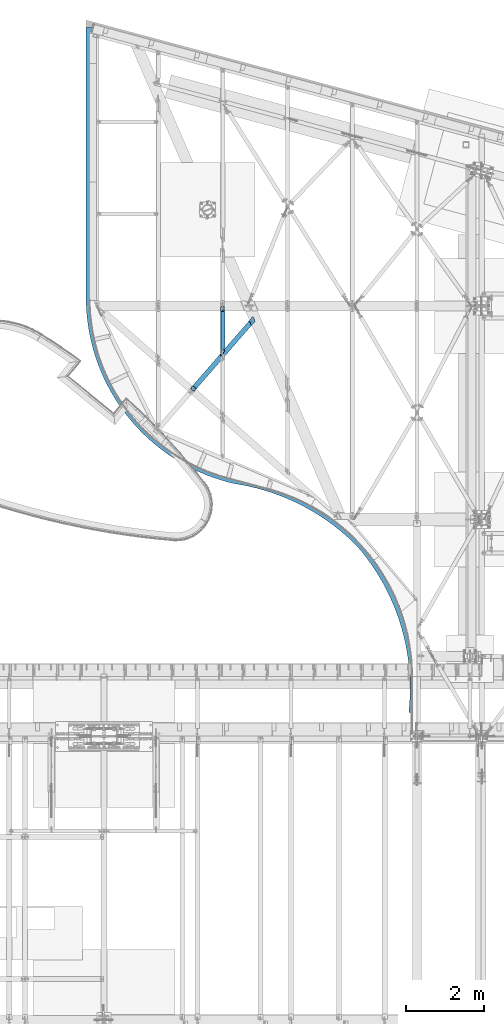
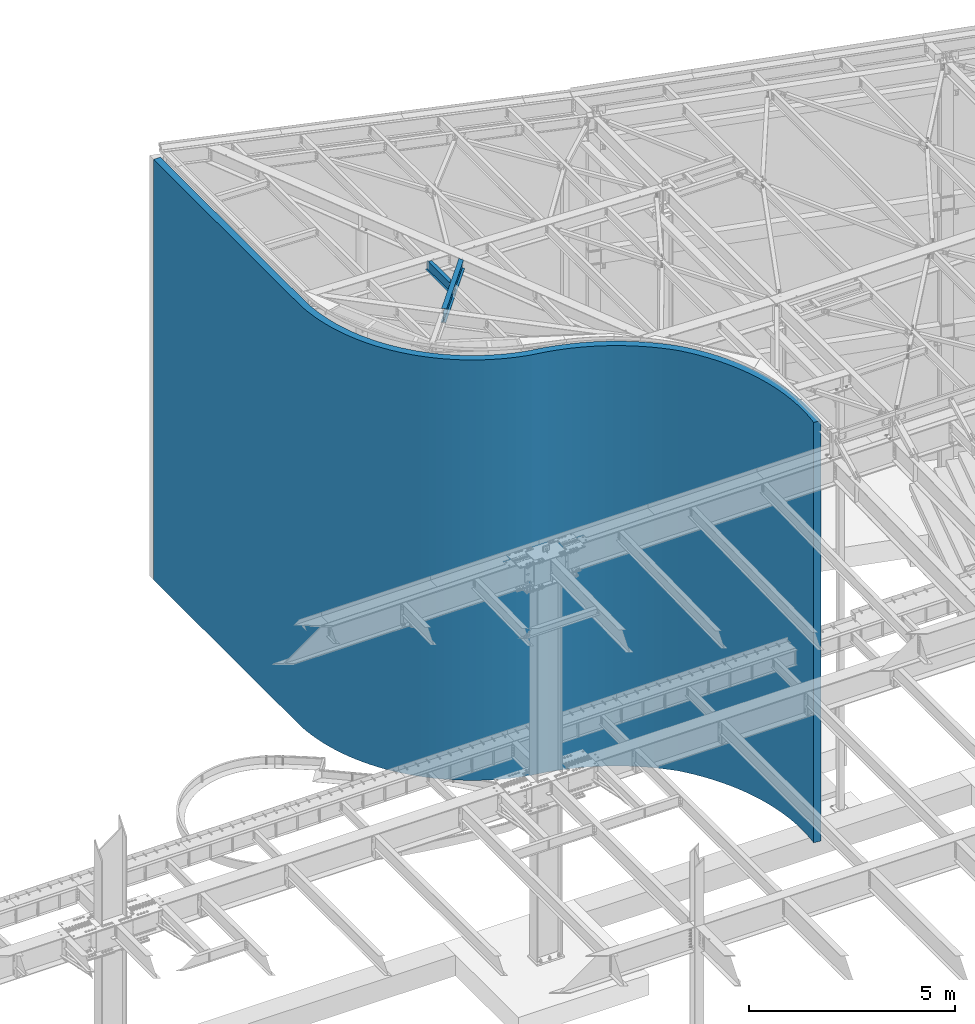
# One storey, part 1154 of 1763: 3 beams, 3 elements without a shape of their own.
"""IFC2X3 building model written with IfcOpenShell, lengths in millimetres."""

from ifc_helpers import new_model, si_unit, frame, origin_with_axes, place, context, subcontext, project, spatial, faceted_brep, material, type_object, element, aggregate, save


model = new_model("IFC2X3")

# Units and contexts
model_context = context("Model", 3, precision=1e-05, world=origin_with_axes())
body_context = subcontext(model_context, "Body", "Model", "MODEL_VIEW")
ifc_project = project(units=[si_unit("LENGTHUNIT", "METRE", prefix="MILLI"), si_unit("AREAUNIT", "SQUARE_METRE"), si_unit("VOLUMEUNIT", "CUBIC_METRE"), si_unit("MASSUNIT", "GRAM", prefix="KILO"), si_unit("TIMEUNIT", "SECOND"), si_unit("PLANEANGLEUNIT", "RADIAN"), si_unit("SOLIDANGLEUNIT", "STERADIAN"), si_unit("THERMODYNAMICTEMPERATUREUNIT", "DEGREE_CELSIUS"), si_unit("LUMINOUSINTENSITYUNIT", "LUMEN")], contexts=[model_context])

# Site, building, storey
site_placement = place(None, origin_with_axes())
site = spatial("IfcSite", under=ifc_project, at=site_placement, CompositionType="ELEMENT")
building_placement = place(site_placement, origin_with_axes())
building = spatial("IfcBuilding", under=site, at=building_placement, Name="Undefined", CompositionType="ELEMENT")
storey_placement = place(building_placement, origin_with_axes())
storey = spatial("IfcBuildingStorey", under=building, at=storey_placement, Name="Undefined", CompositionType="ELEMENT", Elevation=0.0)

# Assembly, beam
assembly_1_placement = place(storey_placement, origin_with_axes())
assembly_1 = element("IfcElementAssembly", 1, at=assembly_1_placement, inside=storey, Name="BEAM", AssemblyPlace="NOTDEFINED", PredefinedType="RIGID_FRAME")
ifc_material_1 = material(Name="STEEL/A992")
beam_type_1 = type_object("IfcBeamType", Name="W14X22", PredefinedType="NOTDEFINED")
beam_1_placement = place(assembly_1_placement, frame((-47136.1523026446, 61032.4432502691, 12491.2715672876), z_axis=(0.0117117683939068, 0.0134686184529928, 0.999840702711215), x_axis=(0.656071853810305, 0.754487344781849, -0.0178485069948396)))
beam_1 = element("IfcBeam", 2, at=beam_1_placement, type_object=beam_type_1, material=ifc_material_1, Name="BEAM", ObjectType="W14X22", context=body_context, shape_type="Brep", body=[
    faceted_brep([(102.648030856568, -63.4999999993015, 174.624999999811), (102.64803083448, 63.5000000006403, 174.624999999825), (94.7072760891588, 63.5000000005966, 166.687499999836), (94.7072760996507, 3.17500000062864, 166.687499999829), (94.7072761007585, -3.17499999936263, 166.687499999829), (94.7072761112504, -63.4999999993452, 166.687499999822), (120.10721292406, 3.1750000007014, 166.687499999813), (120.107212925166, -3.17499999930442, 166.687499999811), (135.206088511542, 3.17500000068685, 155.246997641187), (135.206088512641, -3.17499999928987, 155.246997639388), (24.1332242782682, -63.5000000003347, -166.687499999913), (24.1332242677709, -3.17500000035216, -166.687499999905), (24.1332242666685, 3.17499999962456, -166.687499999905), (24.1332242561821, 63.4999999996071, -166.687499999898), (16.1784383922495, 63.4999999995634, -174.624999999887), (16.1784384143357, -63.5000000003783, -174.624999999902), (41.595682183266, -3.17500000032305, -166.687499999916), (41.5956821821619, 3.17499999968277, -166.687499999915), (57.2176252228219, -3.17500000023574, -155.048752125567), (57.2176252217159, 3.17499999974098, -155.048752123768), (60.3440949831111, -3.17500000023574, -150.229810737879), (60.3440949820033, 3.17499999977008, -150.22981073608), (60.1310959594284, -3.17500000022119, -144.48945877342), (60.1310959583152, 3.17499999978463, -144.489458771621), (56.656096135137, -3.17500000022119, -139.915468668352), (56.6560961340365, 3.17499999978463, -139.915468666552), (51.1829568368503, -3.17500000022119, -138.171405744761), (51.1829568357407, 3.17499999977008, -138.17140574296), (22.3201124317293, -3.17500000029395, -138.108479030428), (22.3201124306215, 3.17499999969732, -138.108479028628), (17.3863228504815, -3.17499999959546, 138.272906307411), (17.3863228493756, 3.17500000039581, 138.272906309212), (129.569880671454, -3.17499999934807, 138.028328858607), (129.569880670344, 3.17500000064319, 138.028328860408), (135.172495285398, -3.17499999933352, 139.835237282246), (135.172495284294, 3.17500000065775, 139.835237284045), (138.643031747935, -3.17499999930442, 144.590191038695), (138.643031746828, 3.1750000006723, 144.590191040495), (138.655863218766, -3.17499999930442, 150.476959584948), (138.655863217655, 3.1750000006723, 150.476959586747), (2316.70283794181, 63.500000005457, 174.624999998396), (2255.83665497571, -63.4999999946158, 174.624999998421), (2255.97834858656, -63.4999999946158, 166.687499998425), (2284.88978549545, -3.1749999945896, 166.687499998414), (2285.39146308625, -3.17499999466236, 138.584144779314), (2288.43477223445, 3.17500000534346, 138.584144783956), (2287.93309464375, 3.17500000541622, 166.687499998414), (2316.84453155264, 63.5000000054424, 166.687499998401), (2286.52766898336, -3.17499999467691, 133.787191069841), (2289.57097813155, 3.17500000532891, 133.787191074483), (2289.59498528674, -3.17499999467691, 129.736321639783), (2292.63829443493, 3.17500000532891, 129.736321644426), (2294.13584209389, -3.17499999467691, 127.035828889026), (2297.17915124207, 3.17500000534346, 127.03582889367), (2299.47285265983, -3.17499999466236, 126.08856145868), (2302.51616180802, 3.17500000534346, 126.088561463324), (2438.31137608543, 3.1750000056345, 126.08856150152), (2435.26806693206, -3.17499999437132, 126.088561496876), (2440.49451488276, -3.17499999508436, -166.687500001466), (2411.58307792498, -63.4999999951106, -166.687500001455), (2411.72477301575, -63.4999999951251, -174.625000001448), (2472.59095608476, 63.5000000049477, -174.625000001473), (2472.44926099399, 63.5000000049477, -166.687500001479), (2443.53782403621, 3.17500000492146, -166.687500001466), (41.5956821937652, -63.5000000002765, -166.687499999924), (41.59568217167, 63.4999999996508, -166.687499999909), (120.107212913566, 63.5000000006548, 166.687499999818), (120.10721293566, -63.4999999992724, 166.687499999805)], [[[0, 1, 2, 3, 4, 5]], [[4, 3, 6, 7]], [[7, 6, 8, 9]], [[10, 11, 12, 13, 14, 15]], [[16, 17, 12, 11]], [[18, 19, 17, 16]], [[20, 21, 19, 18]], [[22, 23, 21, 20]], [[24, 25, 23, 22]], [[26, 27, 25, 24]], [[28, 29, 27, 26]], [[30, 31, 29, 28]], [[32, 33, 31, 30]], [[34, 35, 33, 32]], [[36, 37, 35, 34]], [[38, 39, 37, 36]], [[9, 8, 39, 38]], [[40, 41, 42, 43, 44, 45, 46, 47]], [[45, 44, 48, 49]], [[49, 48, 50, 51]], [[51, 50, 52, 53]], [[53, 52, 54, 55]], [[56, 55, 54, 57]], [[58, 59, 60, 61, 62, 63, 56, 57]], [[64, 59, 58, 16, 11, 10]], [[60, 59, 64, 10, 15]], [[61, 60, 15, 14]], [[65, 62, 61, 14, 13]], [[17, 63, 62, 65, 13, 12]], [[6, 46, 45, 49, 51, 53, 55, 56, 63, 17, 19, 21, 23, 25, 27, 29, 31, 33, 35, 37, 39, 8]], [[66, 47, 46, 6, 3, 2]], [[40, 47, 66, 2, 1]], [[41, 40, 1, 0]], [[67, 42, 41, 0, 5]], [[7, 43, 42, 67, 5, 4]], [[34, 32, 30, 28, 26, 24, 22, 20, 18, 16, 58, 57, 54, 52, 50, 48, 44, 43, 7, 9, 38, 36]]]),
])
aggregate(assembly_1, [beam_1])

assembly_2_placement = place(storey_placement, origin_with_axes())
assembly_2 = element("IfcElementAssembly", 3, at=assembly_2_placement, inside=storey, Name="BEAM", AssemblyPlace="NOTDEFINED", PredefinedType="RIGID_FRAME")
beam_type_2 = type_object("IfcBeamType", Name="W12X16", PredefinedType="NOTDEFINED")
beam_2_placement = place(assembly_2_placement, frame((-46340.5472371989, 61952.4512306199, 12489.8609543434), z_axis=(0.0294363099980619, 0.0, 0.999566657934176), x_axis=(0.0, 1.0, 0.0)))
beam_2 = element("IfcBeam", 4, at=beam_2_placement, type_object=beam_type_2, material=ifc_material_1, Name="BEAM", ObjectType="W12X16", context=body_context, shape_type="Brep", body=[
    faceted_brep([(101.6206411612, -3.17499999982829, 114.930459316774), (94.3212600383195, 3.17500000017753, 114.930459316782), (19.3776820834391, 3.17500000017753, 114.930459305668), (26.6770632049593, -3.17499999982829, 114.93045930569), (109.025480020275, -3.17499999982101, 115.897189240532), (101.726098897387, 3.17500000017753, 115.897189240541), (115.302999287371, -3.17499999982101, 118.650203142006), (108.00361816449, 3.17500000018481, 118.650203142013), (119.497503559942, -3.17499999981374, 122.770379610831), (112.198122437054, 3.17500000018481, 122.77037961084), (120.970417585748, -3.17499999980646, 127.630459129117), (113.671036462867, 3.17500000019209, 127.630459129126), (175.715775997553, -50.7999999997774, 152.400000000001), (58.9256780317446, 50.800000000243, 152.400000000031), (58.9256780340947, 50.8000000002285, 146.05000000003), (113.671036455569, 3.17500000022119, 146.050000000017), (120.970417578435, -3.17499999978463, 146.050000000014), (175.715775999903, -50.7999999997919, 146.050000000003), (17.8423608078956, -3.17500000023574, -146.050000000021), (72.5877192192638, -50.8000000002357, -146.050000000032), (1230.84251937904, -50.8000000002357, -146.050000000032), (1230.84251937904, -3.17500000023574, -146.050000000021), (72.3727592166251, -50.8000000002576, -152.400000000032), (1230.84251937904, -50.8000000002576, -152.400000000032), (-44.4173387276387, 50.7999999997774, -152.400000000003), (1230.84251937904, 50.7999999997774, -152.400000000003), (-44.202378725, 50.7999999997846, -146.050000000005), (1230.84251937904, 50.7999999997846, -146.050000000005), (10.5429796863755, 3.17499999977008, -146.050000000016), (1230.84251937904, 3.17499999977008, -146.050000000016), (1230.84251937904, 3.17500000016298, 107.996414205025), (1230.84251937904, -3.17499999983556, 107.996414205032), (1118.92377529181, 3.17500000016298, 107.996414205256), (1118.92377529181, -3.17499999983556, 107.996414205241), (1114.06369577376, 3.17500000016298, 108.963144127843), (1114.06369577376, -3.17499999983556, 108.963144127831), (1109.94351930561, 3.17500000017026, 111.716158028323), (1109.94351930561, -3.17499999982829, 111.71615802831), (1107.19050540513, 3.17500000017753, 115.836334496478), (1107.19050540513, -3.17499999982101, 115.836334496465), (1106.22377548254, 3.17500000017753, 120.696414014525), (1106.22377548254, -3.17499999982101, 120.696414014512), (1106.22377548254, -50.7999999997774, 152.400000000001), (1106.22377548254, -50.7999999997919, 146.050000000003), (1106.22377548254, -3.17499999978463, 146.050000000014), (1106.22377548254, 3.17500000022119, 146.050000000017), (1106.22377548254, 50.8000000002285, 146.05000000003), (1106.22377548254, 50.800000000243, 152.400000000031)], [[[0, 1, 2, 3]], [[4, 5, 1, 0]], [[6, 7, 5, 4]], [[8, 9, 7, 6]], [[10, 11, 9, 8]], [[12, 13, 14, 15, 11, 10, 16, 17]], [[18, 19, 20, 21]], [[19, 22, 23, 20]], [[22, 24, 25, 23]], [[24, 26, 27, 25]], [[26, 28, 29, 27]], [[21, 20, 23, 25, 27, 29, 30, 31]], [[31, 30, 32, 33]], [[33, 32, 34, 35]], [[35, 34, 36, 37]], [[37, 36, 38, 39]], [[39, 38, 40, 41]], [[42, 43, 44, 41, 40, 45, 46, 47]], [[43, 42, 12, 17]], [[44, 43, 17, 16]], [[8, 6, 4, 0, 3, 18, 21, 31, 33, 35, 37, 39, 41, 44, 16, 10]], [[28, 26, 24, 22, 19, 18, 3, 2]], [[45, 40, 38, 36, 34, 32, 30, 29, 28, 2, 1, 5, 7, 9, 11, 15]], [[46, 45, 15, 14]], [[47, 46, 14, 13]], [[42, 47, 13, 12]]]),
])
aggregate(assembly_2, [beam_2])

assembly_3_placement = place(storey_placement, origin_with_axes())
assembly_3 = element("IfcElementAssembly", 5, at=assembly_3_placement, inside=storey, Name="WALL", AssemblyPlace="NOTDEFINED", PredefinedType="REINFORCEMENT_UNIT")
ifc_material_2 = material(Name="CONCRETE/5000")
beam_type_3 = type_object("IfcBeamType", PredefinedType="NOTDEFINED")
beam_3_placement = place(assembly_3_placement, frame((-49762.5854609542, 70370.1130240262, 6223.0), z_axis=(0.0, 0.0, 1.0), x_axis=(0.0, -1.0, 0.0)))
beam_3 = element("IfcBeam", 6, at=beam_3_placement, type_object=beam_type_3, material=ifc_material_2, Name="WALL", context=body_context, shape_type="Brep", body=[
    faceted_brep([(5.82076609134674e-11, -95.25, -6223.0), (5.82076609134674e-11, -95.25, 6223.0), (-5.82076609134674e-11, 95.25, 6223.0), (-5.82076609134674e-11, 95.25, -6223.0), (7160.16255788686, 95.2500000041327, 6222.99994910497), (7160.16255782155, 95.2500000041327, -6223.00005089503), (7159.16643113189, -95.2499999958673, 6222.99994910497), (7159.16643113189, -95.2499999958673, -6223.00005089503), (7164.41053620569, -95.2499999958673, -6223.00005089503), (7164.410536271, -95.2499999958673, 6222.99994910497), (7161.15769442133, 95.2944033816166, 6222.99994905435), (7161.1576936047, 95.2944216605028, -6223.0000506656), (7169.64942867619, -95.0162385944568, -6223.00005094565), (7169.64942867619, -95.0162385944568, 6222.99994905435), (7346.80603772437, 107.242026553351, 6222.99994938726), (7346.80604171794, 107.24206347303, -6223.00005061274), (7362.77870309409, -82.5871336714772, -6223.0000511707), (7362.77869910051, -82.5871705911559, 6222.9999488293), (7555.26944160913, -62.5692733118194, -6223.00005100577), (7555.26943201036, -62.5693108141641, 6222.99994899423), (7531.84057744646, 126.484487808841, 6222.9999495458), (7531.84058704521, 126.484525311185, -6223.0000504542), (7746.82356827322, -34.9936372284283, -6223.00005073117), (7746.82355309652, -34.9936755335148, 6222.99994926884), (7715.9747853184, 152.991971595562, 6222.99994980977), (7715.97480049508, 152.992009900641, -6223.00005019023), (7937.1444583141, 0.0970732445348403, -6223.00005034731), (7937.14443759537, 0.0970339178675204, 6222.9999496527), (7898.92352643642, 186.723430631049, 6222.99995017876), (7898.92354715514, 186.723469957709, -6223.00004982124), (8125.93739664706, 42.6485195543937, -6223.00004985479), (8125.93737043077, 42.6484789888927, 6222.99995014521), (8080.40350161184, 227.626631186242, 6222.9999506522), (8080.40352782812, 227.626671751736, -6223.0000493478), (8312.91003424619, 92.5948100741007, -6223.00004925437), (8312.91000258533, 92.5947680544268, 6222.99995074563), (8260.13368606465, 275.63823397024, 6222.99995122936), (8260.1337177255, 275.638275989913, -6223.00004877064), (8497.77284085175, 149.858602136563, -6223.00004854699), (8497.77280380773, 149.858558449632, 6222.99995145301), (8437.83576459505, 330.683892212306, 6222.99995190934), (8437.83580163906, 330.683935899229, -6223.00004809066), (8680.23955331263, 214.351221801022, -6223.00004773374), (8680.23951095519, 214.351176236327, 6222.99995226626), (8613.23456255924, 392.678366789027, 6222.99995269109), (8613.23460491665, 392.678412353715, -6223.00004730892), (8860.02761886957, 285.972801166143, -6223.00004681588), (8860.02757127672, 285.972753516086, 6222.99995318412), (8786.05847198192, 461.525658218576, 6222.9999535734), (8786.05851957475, 461.525705868618, -6223.00004642661), (9036.85863269294, 364.612433017151, -6223.00004579483), (9036.85857995076, 364.612383077365, 6222.99995420517), (8956.03987214582, 537.119155317479, 6222.9999545549), (8956.03992488798, 537.119205257251, -6223.00004544511), (9210.45876899723, 450.148342567481, -6223.00004467217), (9210.45871119978, 450.148290137142, 6222.99995532783), (9122.91554400685, 619.341800289847, 6222.99995563407), (9122.91560180428, 619.341852720172, -6223.00004436593), (9380.55920506483, 542.448076029097, -6223.00004344964), (9380.55914231401, 542.44802091123, 6222.99995655037), (9286.42707779318, 708.066269993309, 6222.99995680925), (9286.42714054398, 708.066325111162, -6223.00004319076), (9546.89653752254, 641.368705719397, -6223.00004212913), (9546.8964699279, 641.368647721196, 6222.99995787087), (9446.32127315713, 803.155173101048, 6222.9999580786), (9446.32134075175, 803.155231099234, -6223.0000419214), (9709.21319022613, 746.757051387103, -6223.00004071269), (9709.21311790476, 746.756990320224, 6222.99995928732), (9602.35053126012, 904.461262854558, 6222.99995944018), (9602.35060358148, 904.461323921423, -6223.00004055982), (9867.25781312128, 858.449917414466, -6223.00003920251), (9867.25773619754, 858.449853095313, 6222.9999607975), (9754.27323818364, 1011.82766507772, 6222.99996089186), (9754.27331510736, 1011.82772939686, -6223.00003910814), (10020.7856714633, 976.274345528414, -6223.00003760092), (10020.7855900688, 976.274277778422, 6222.99996239908), (9901.85413907241, 1125.0881210991, 6222.9999624314), (9901.85422046699, 1125.08818884908, -6223.0000375686), (10169.5590247932, 1100.04788262931, -6223.00003591042), (10169.5589390662, 1100.04781127523, 6222.99996408958), (10044.8647024305, 1244.06724520625, 6222.99996405642), (10044.8647881575, 1244.06731656032, -6223.00003594358), (10313.3474950824, 1229.57886332266, -6223.00003413362), (10313.3474051681, 1229.57878819682, 6222.99996586638), (10183.0834740062, 1368.58079623347, 6222.9999657644), (10183.0835639205, 1368.5808713593, -6223.0000342356), (10451.9284234772, 1364.66670671616, -6223.00003227326), (10451.9283295273, 1364.66662765674, 6222.99996772674), (10316.2964197176, 1498.43596286231, 6222.9999675527), (10316.2965136675, 1498.43604192173, -6223.00003244731), (10585.0872150899, 1505.10222702259, -6223.00003033224), (10585.0871172622, 1505.10214387385, 6222.99996966776), (10444.2972570879, 1633.43166219312, 6222.99996941854), (10444.2973549155, 1633.43174534186, -6223.00003058147), (10712.6176713022, 1650.66795748749, -6223.00002831355), (10712.6175697606, 1650.66787010001, 6222.99997168645), (10566.8877746773, 1773.3588511253, 6222.99997135903), (10566.8878762188, 1773.35893851276, -6223.00002864097), (10834.3223090674, 1801.13848714008, -6223.00002622032), (10834.3222039816, 1801.13839537102, 6222.99997377969), (10683.8781390169, 1918.00085006403, 6222.99997337118), (10683.8782441027, 1918.00094183306, -6223.00002662882), (10950.0126667163, 1956.28080984591, -6223.00002405579), (10950.0125582613, 1956.28071355922, 6222.99997594421), (10795.0871885687, 2067.13367845225, 6222.99997545186), (10795.0872970236, 2067.13377473892, -6223.00002454814), (11059.5095957931, 2115.85468512076, -6223.00002182332), (11059.5094841494, 2115.85458418739, 6222.99997817668), (10900.3427142576, 2220.52640160833, 6222.99997759786), (10900.3428259013, 2220.5265025417, -6223.00002240214), (11162.6435384698, 2279.61301014711, -6223.00001952636), (11162.6434238227, 2279.61290444516, 6222.99998047364), (10999.4817261399, 2377.94148833227, 6222.99997980585), (10999.481840787, 2377.94159403419, -6223.00002019416), (11259.2547901096, 2447.30220241687, -6223.00001716846), (11259.2546726489, 2447.30209183188, 6222.99998283154), (11092.3507057956, 2539.13517872671, 6222.9999820724), (11092.3508232564, 2539.13528931169, -6223.0000179276), (11349.1937465717, 2618.66259240826, -6223.00001475329), (11349.1936264917, 2618.6624768333, 6222.99998524671), (11178.8058440551, 2703.85786166327, 6222.99998439402), (11178.8059641351, 2703.85797723822, -6223.00001560598), (11432.3211358762, 2793.42882568836, -6223.00001228458), (11432.3210133753, 2793.42870502422, 6222.99998771542), (11258.7132636892, 2871.85446130953, 6222.99998676711), (11258.7133861901, 2871.85458197365, -6223.00001323289), (11508.508233869, 2971.33027381886, -6223.00000976615), (11508.5081091492, 2971.33014797424, 6222.99999023385), (11331.9492267207, 3042.86483211821, 6222.99998918799), (11331.9493514404, 3042.86495796282, -6223.00001081201), (11577.6370635532, 3152.09145342881, -6223.0000072019), (11577.6369368201, 3152.0913223204, 6222.9999927981), (11398.4003260347, 3216.62416166696, 6222.99999165291), (11398.4004527677, 3216.62429277536, -6223.00000834709), (11639.6005777787, 3335.43245280514, -6223.0000045958), (11639.6004492411, 3335.43231635781, 6222.9999954042), (11457.9636609913, 3392.86338072478, 6222.99999415806), (11457.963789529, 3392.86351717209, -6223.00000584195), (11694.3028250064, 3521.06936534071, -6223.0000019519), (11694.3026948755, 3521.06922348758, 6222.9999980481), (11510.5469967692, 3571.30957991023, 6222.99999669955), (11510.5471269001, 3571.30972176335, -6223.00000330045), (11741.65909789, 3708.71472916681, -6222.99999927427), (11741.6589663787, 3708.71458184431, 6223.00000072573), (11556.068907191, 3751.68643228968, 6222.99999927346), (11556.0689733391, 3751.68650764776, -6223.0), (11556.2939983045, 3752.65836230947, 6223.0), (11556.2939983045, 3752.65836230947, -6223.0), (11743.5826917223, 3717.02270050324, -6223.0), (11743.5826917223, 3717.02270050324, 6223.0), (11556.4423285532, 3753.64976218137, 6223.0), (11556.4423285534, 3753.64976218138, -6223.0), (11744.8452768499, 3725.46148317811, -6223.0), (11744.8452768499, 3725.46148317811, 6223.0), (11590.8117237126, 3958.16596217194, 6223.0), (11590.8117237126, 3958.16596217194, -6223.0), (11778.0793607708, 3923.22197684392, -6223.0), (11778.0793607708, 3923.22197684392, 6223.0), (11818.4023343206, 4119.65968960067, -6223.0), (11818.4023343206, 4119.65968960067, 6223.0), (11632.5121724215, 4161.31419366739, 6223.0), (11632.5121724215, 4161.31419366739, -6223.0), (11865.7620541097, 4314.52059930427, -6223.0), (11865.7620541097, 4314.52059930427, 6223.0), (11681.4897500172, 4362.83175686004, 6223.0), (11681.4897500172, 4362.83175686004, -6223.0), (11920.097277226, 4507.55272284312, -6223.0), (11920.097277226, 4507.55272284312, 6223.0), (11737.6811214655, 4562.45806063037, 6223.0), (11737.6811214655, 4562.45806063037, -6223.0), (11981.3377404308, 4698.50644198855, -6223.0), (11981.3377404308, 4698.50644198855, 6223.0), (11801.0136232618, 4759.93495952863, 6223.0), (11801.0136232618, 4759.93495952863, -6223.0), (12049.4042510195, 4887.13482618692, -6223.0), (12049.4042510195, 4887.13482618692, 6223.0), (11871.4053573952, 4955.00708759393, 6223.0), (11871.4053573952, 4955.00708759393, -6223.0), (12124.2087892289, 5073.19395187627, -6223.0), (12124.2087892289, 5073.19395187627, 6223.0), (11948.7652972551, 5147.42218857908, 6223.0), (11948.7652972551, 5147.42218857907, -6223.0), (12205.6546220594, 5256.44321791452, -6223.0), (12205.6546220594, 5256.44321791452, 6223.0), (12032.9934053409, 5336.93144215403, 6223.0), (12032.9934053409, 5336.93144215403, -6223.0), (12293.6364283647, 5436.64565671116, -6223.0), (12293.6364283647, 5436.64565671116, 6223.0), (12123.9807626252, 5523.28978566638, 6223.0), (12123.9807626252, 5523.28978566638, -6223.0), (12388.0404350472, 5613.56824066048, -6223.0), (12388.0404350472, 5613.56824066048, 6223.0), (12221.6097094017, 5706.25623104245, 6223.0), (12221.6097094017, 5706.25623104245, -6223.0), (12488.7445641827, 5786.98218347961, -6223.0), (12488.7445641827, 5786.98218347961, 6223.0), (12325.7539974361, 5885.59417641947, 6223.0), (12325.7539974361, 5885.59417641947, -6223.0), (12595.6185908849, 5956.66323606199, -6223.0), (12595.6185908849, 5956.66323606199, 6223.0), (12436.2789532231, 6061.0717121057, 6223.0), (12436.2789532231, 6061.0717121057, -6223.0), (12708.5243117048, 6122.3919764637, -6223.0), (12708.5243117048, 6122.3919764637, 6223.0), (12553.0416521387, 6232.461920473, 6223.0), (12553.0416521387, 6232.461920473, -6223.0), (12827.3157233477, 6283.95409364747, -6223.0), (12827.3157233477, 6283.95409364747, 6223.0), (12675.8911032621, 6399.54316939379, 6223.0), (12675.8911032621, 6399.54316939379, -6223.0), (12951.8392114761, 6441.1406646176, -6223.0), (12951.8392114761, 6441.1406646176, 6223.0), (12804.6684446286, 6562.09939884325, 6223.0), (12804.6684446286, 6562.09939884325, -6223.0), (13081.9337493553, 6593.74842458738, -6223.0), (13081.9337493553, 6593.74842458738, 6223.0), (12939.207148661, 6719.92040029591, 6223.0), (12939.207148661, 6719.92040029591, -6223.0), (13217.4311060842, 6741.5800298296, -6223.0), (13217.4311060842, 6741.5800298296, 6223.0), (13079.3332375137, 6872.80208855542, 6223.0), (13079.3332375137, 6872.80208855542, -6223.0), (13358.1560641416, 6884.44431287029, -6223.0), (13358.1560641416, 6884.44431287029, 6223.0), (13224.865508051, 7020.54676566598, 6223.0), (13224.8655080523, 7020.54676566806, -6223.0), (13229.8485845107, 7025.42689103353, 6223.0), (13229.8485845107, 7025.42689103353, -6223.0), (13358.8705126799, 6885.14400079741, -6223.0), (13358.8705126799, 6885.14400079741, 6223.0), (13235.1276848818, 7029.98516407561, 6223.0), (13235.1276848819, 7029.98516407568, -6223.0), (13359.6274073271, 6885.79754633039, -6223.0), (13359.6274073271, 6885.79754633039, 6223.0), (13671.934677244, 7136.49914220754, 6223.0), (13834.625324312, 7253.29561504574, 6223.0), (14001.3971333595, 7364.18667157355, 6223.0), (14172.0358487299, 7469.02984744849, 6223.0), (14346.3222468615, 7567.69044818222, 6223.0), (14524.0324179288, 7660.04172218582, 6223.0), (14704.9380535047, 7745.96502361044, 6223.0), (14888.8067398741, 7825.34996477448, 6223.0), (15075.4022566209, 7898.09455798114, 6223.0), (15264.4848801061, 7964.10534654451, 6223.0), (15455.8116914464, 8023.2975248555, 6223.0), (15649.1368885974, 8075.59504733364, 6223.0), (15844.2121021417, 8120.93072612458, 6223.0), (16040.786714375, 8159.24631741791, 6223.0), (16238.60818128, 8190.49259627439, 6223.0), (16437.4223569761, 8214.62941986635, 6223.0), (16636.9738202263, 8231.62577905012, 6223.0), (16837.0062025832, 8241.45983820421, 6223.0), (17037.2625177511, 8244.11896328208, 6223.0), (17237.4854917427, 8239.59973804332, 6223.0), (17437.4178934048, 8227.90796844266, 6223.0), (17636.8028648878, 8209.05867517106, 6223.0), (17658.1282715528, 8398.36128220704, 6223.0), (17451.9455103845, 8417.85321935706, 6223.0), (17245.1966550662, 8429.94360571507, 6223.0), (17038.1473207059, 8434.61690847774, 6223.0), (16831.0635084423, 8431.86712374336, 6223.0), (16624.2112637082, 8421.69778422489, 6223.0), (16417.8563344367, 8404.12195471145, 6223.0), (16212.2638296476, 8379.16221528366, 6223.0), (16007.6978788564, 8346.85063230445, 6223.0), (15804.4212927403, 8307.22871722272, 6223.0), (15602.6952254997, 8260.34737324253, 6223.0), (15402.7788393468, 8206.26682992663, 6223.0), (15204.9289715543, 8145.05656581806, 6223.0), (15009.39980449, 8076.7952191795, 6223.0), (14816.4425390632, 8001.5704869648, 6223.0), (14626.3050720008, 7919.47901215267, 6223.0), (14439.2316773684, 7830.62625958716, 6223.0), (14255.462692746, 7735.12638048452, 6223.0), (14075.2342104605, 7633.10206578045, 6223.0), (13898.7777742724, 7524.68438850615, 6223.0), (13726.320081906, 7410.01263539577, 6223.0), (13558.0826938055, 7289.23412794143, 6223.0), (13394.2817484914, 7162.50403312584, 6223.0), (13513.5342046476, 7013.94730422836, 6223.0), (13394.2817484914, 7162.50403312584, -6223.0), (13558.0826938055, 7289.23412794143, -6223.0), (13726.320081906, 7410.01263539577, -6223.0), (13898.7777742724, 7524.68438850615, -6223.0), (14075.2342104605, 7633.10206578045, -6223.0), (14255.462692746, 7735.12638048452, -6223.0), (14439.2316773684, 7830.62625958716, -6223.0), (14626.3050720008, 7919.47901215267, -6223.0), (14816.4425390632, 8001.5704869648, -6223.0), (15009.39980449, 8076.7952191795, -6223.0), (15204.9289715543, 8145.05656581806, -6223.0), (15402.7788393468, 8206.26682992663, -6223.0), (15602.6952254997, 8260.34737324253, -6223.0), (15804.4212927403, 8307.22871722272, -6223.0), (16007.6978788564, 8346.85063230445, -6223.0), (16212.2638296476, 8379.16221528366, -6223.0), (16417.8563344367, 8404.12195471145, -6223.0), (16624.2112637082, 8421.69778422489, -6223.0), (16831.0635084423, 8431.86712374336, -6223.0), (17038.1473207059, 8434.61690847774, -6223.0), (17245.1966550662, 8429.94360571507, -6223.0), (17451.9455103845, 8417.85321935706, -6223.0), (17658.1282715528, 8398.36128220704, -6223.0), (17636.8028648878, 8209.05867517106, -6223.0), (17437.4178934048, 8227.90796844266, -6223.0), (17237.4854917427, 8239.59973804332, -6223.0), (17037.2625177511, 8244.11896328208, -6223.0), (16837.0062025832, 8241.45983820421, -6223.0), (16636.9738202263, 8231.62577905012, -6223.0), (16437.4223569761, 8214.62941986635, -6223.0), (16238.60818128, 8190.49259627439, -6223.0), (16040.786714375, 8159.24631741791, -6223.0), (15844.2121021417, 8120.93072612458, -6223.0), (15649.1368885974, 8075.59504733364, -6223.0), (15455.8116914464, 8023.2975248555, -6223.0), (15264.4848801061, 7964.10534654451, -6223.0), (15075.4022566209, 7898.09455798114, -6223.0), (14888.8067398741, 7825.34996477448, -6223.0), (14704.9380535047, 7745.96502361044, -6223.0), (14524.0324179288, 7660.04172218582, -6223.0), (14346.3222468615, 7567.69044818222, -6223.0), (14172.0358487299, 7469.02984744849, -6223.0), (14001.3971333595, 7364.18667157355, -6223.0), (13834.625324312, 7253.29561504574, -6223.0), (13671.934677244, 7136.49914220754, -6223.0), (13513.5342046476, 7013.94730422836, -6223.0)], [[[0, 1, 2, 3]], [[3, 2, 4, 5]], [[6, 1, 0, 7, 8, 9]], [[5, 4, 10, 11]], [[9, 8, 12, 13]], [[11, 10, 14, 15]], [[13, 12, 16, 17]], [[16, 18, 19, 17]], [[14, 20, 21, 15]], [[18, 22, 23, 19]], [[20, 24, 25, 21]], [[22, 26, 27, 23]], [[24, 28, 29, 25]], [[26, 30, 31, 27]], [[28, 32, 33, 29]], [[30, 34, 35, 31]], [[32, 36, 37, 33]], [[34, 38, 39, 35]], [[36, 40, 41, 37]], [[38, 42, 43, 39]], [[40, 44, 45, 41]], [[42, 46, 47, 43]], [[44, 48, 49, 45]], [[46, 50, 51, 47]], [[48, 52, 53, 49]], [[50, 54, 55, 51]], [[52, 56, 57, 53]], [[54, 58, 59, 55]], [[56, 60, 61, 57]], [[58, 62, 63, 59]], [[60, 64, 65, 61]], [[62, 66, 67, 63]], [[64, 68, 69, 65]], [[66, 70, 71, 67]], [[68, 72, 73, 69]], [[70, 74, 75, 71]], [[72, 76, 77, 73]], [[74, 78, 79, 75]], [[76, 80, 81, 77]], [[78, 82, 83, 79]], [[80, 84, 85, 81]], [[82, 86, 87, 83]], [[84, 88, 89, 85]], [[86, 90, 91, 87]], [[88, 92, 93, 89]], [[90, 94, 95, 91]], [[92, 96, 97, 93]], [[94, 98, 99, 95]], [[96, 100, 101, 97]], [[98, 102, 103, 99]], [[100, 104, 105, 101]], [[102, 106, 107, 103]], [[104, 108, 109, 105]], [[106, 110, 111, 107]], [[108, 112, 113, 109]], [[110, 114, 115, 111]], [[112, 116, 117, 113]], [[114, 118, 119, 115]], [[116, 120, 121, 117]], [[118, 122, 123, 119]], [[120, 124, 125, 121]], [[122, 126, 127, 123]], [[124, 128, 129, 125]], [[126, 130, 131, 127]], [[128, 132, 133, 129]], [[130, 134, 135, 131]], [[132, 136, 137, 133]], [[134, 138, 139, 135]], [[136, 140, 141, 137]], [[138, 142, 143, 139]], [[140, 144, 145, 141]], [[145, 144, 146, 147]], [[143, 142, 148, 149]], [[147, 146, 150, 151]], [[149, 148, 152, 153]], [[151, 150, 154, 155]], [[153, 152, 156, 157]], [[156, 158, 159, 157]], [[154, 160, 161, 155]], [[158, 162, 163, 159]], [[160, 164, 165, 161]], [[162, 166, 167, 163]], [[164, 168, 169, 165]], [[166, 170, 171, 167]], [[168, 172, 173, 169]], [[170, 174, 175, 171]], [[172, 176, 177, 173]], [[174, 178, 179, 175]], [[176, 180, 181, 177]], [[178, 182, 183, 179]], [[180, 184, 185, 181]], [[182, 186, 187, 183]], [[184, 188, 189, 185]], [[186, 190, 191, 187]], [[188, 192, 193, 189]], [[190, 194, 195, 191]], [[192, 196, 197, 193]], [[194, 198, 199, 195]], [[196, 200, 201, 197]], [[198, 202, 203, 199]], [[200, 204, 205, 201]], [[202, 206, 207, 203]], [[204, 208, 209, 205]], [[206, 210, 211, 207]], [[208, 212, 213, 209]], [[210, 214, 215, 211]], [[212, 216, 217, 213]], [[214, 218, 219, 215]], [[216, 220, 221, 217]], [[218, 222, 223, 219]], [[220, 224, 225, 221]], [[225, 224, 226, 227]], [[223, 222, 228, 229]], [[227, 226, 230, 231]], [[229, 228, 232, 233]], [[234, 235, 236, 237, 238, 239, 240, 241, 242, 243, 244, 245, 246, 247, 248, 249, 250, 251, 252, 253, 254, 255, 256, 257, 258, 259, 260, 261, 262, 263, 264, 265, 266, 267, 268, 269, 270, 271, 272, 273, 274, 275, 276, 277, 278, 230, 226, 224, 220, 216, 212, 208, 204, 200, 196, 192, 188, 184, 180, 176, 172, 168, 164, 160, 154, 150, 146, 144, 140, 136, 132, 128, 124, 120, 116, 112, 108, 104, 100, 96, 92, 88, 84, 80, 76, 72, 68, 64, 60, 56, 52, 48, 44, 40, 36, 32, 28, 24, 20, 14, 10, 4, 2, 1, 6, 9, 13, 17, 19, 23, 27, 31, 35, 39, 43, 47, 51, 55, 59, 63, 67, 71, 75, 79, 83, 87, 91, 95, 99, 103, 107, 111, 115, 119, 123, 127, 131, 135, 139, 143, 149, 153, 157, 159, 163, 167, 171, 175, 179, 183, 187, 191, 195, 199, 203, 207, 211, 215, 219, 223, 229, 233, 279]], [[231, 230, 278, 280]], [[281, 282, 283, 284, 285, 286, 287, 288, 289, 290, 291, 292, 293, 294, 295, 296, 297, 298, 299, 300, 301, 302, 303, 304, 305, 306, 307, 308, 309, 310, 311, 312, 313, 314, 315, 316, 317, 318, 319, 320, 321, 322, 323, 324, 325, 232, 228, 222, 218, 214, 210, 206, 202, 198, 194, 190, 186, 182, 178, 174, 170, 166, 162, 158, 156, 152, 148, 142, 138, 134, 130, 126, 122, 118, 114, 110, 106, 102, 98, 94, 90, 86, 82, 78, 74, 70, 66, 62, 58, 54, 50, 46, 42, 38, 34, 30, 26, 22, 18, 16, 12, 8, 7, 0, 3, 5, 11, 15, 21, 25, 29, 33, 37, 41, 45, 49, 53, 57, 61, 65, 69, 73, 77, 81, 85, 89, 93, 97, 101, 105, 109, 113, 117, 121, 125, 129, 133, 137, 141, 145, 147, 151, 155, 161, 165, 169, 173, 177, 181, 185, 189, 193, 197, 201, 205, 209, 213, 217, 221, 225, 227, 231, 280]], [[233, 232, 325, 279]], [[325, 324, 234, 279]], [[278, 277, 281, 280]], [[324, 323, 235, 234]], [[277, 276, 282, 281]], [[323, 322, 236, 235]], [[276, 275, 283, 282]], [[322, 321, 237, 236]], [[275, 274, 284, 283]], [[321, 320, 238, 237]], [[274, 273, 285, 284]], [[320, 319, 239, 238]], [[273, 272, 286, 285]], [[319, 318, 240, 239]], [[272, 271, 287, 286]], [[318, 317, 241, 240]], [[271, 270, 288, 287]], [[317, 316, 242, 241]], [[270, 269, 289, 288]], [[316, 315, 243, 242]], [[269, 268, 290, 289]], [[315, 314, 244, 243]], [[268, 267, 291, 290]], [[314, 313, 245, 244]], [[267, 266, 292, 291]], [[313, 312, 246, 245]], [[266, 265, 293, 292]], [[312, 311, 247, 246]], [[265, 264, 294, 293]], [[311, 310, 248, 247]], [[264, 263, 295, 294]], [[310, 309, 249, 248]], [[263, 262, 296, 295]], [[309, 308, 250, 249]], [[262, 261, 297, 296]], [[308, 307, 251, 250]], [[261, 260, 298, 297]], [[307, 306, 252, 251]], [[260, 259, 299, 298]], [[306, 305, 253, 252]], [[259, 258, 300, 299]], [[305, 304, 254, 253]], [[258, 257, 301, 300]], [[255, 303, 302, 256]], [[304, 303, 255, 254]], [[257, 256, 302, 301]]]),
])
aggregate(assembly_3, [beam_3])

save(model, "model.ifc")
